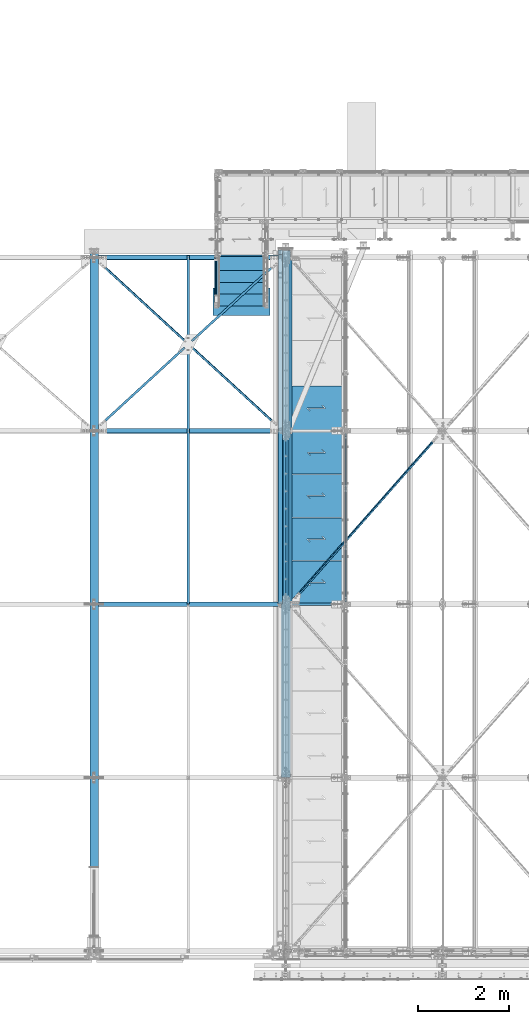
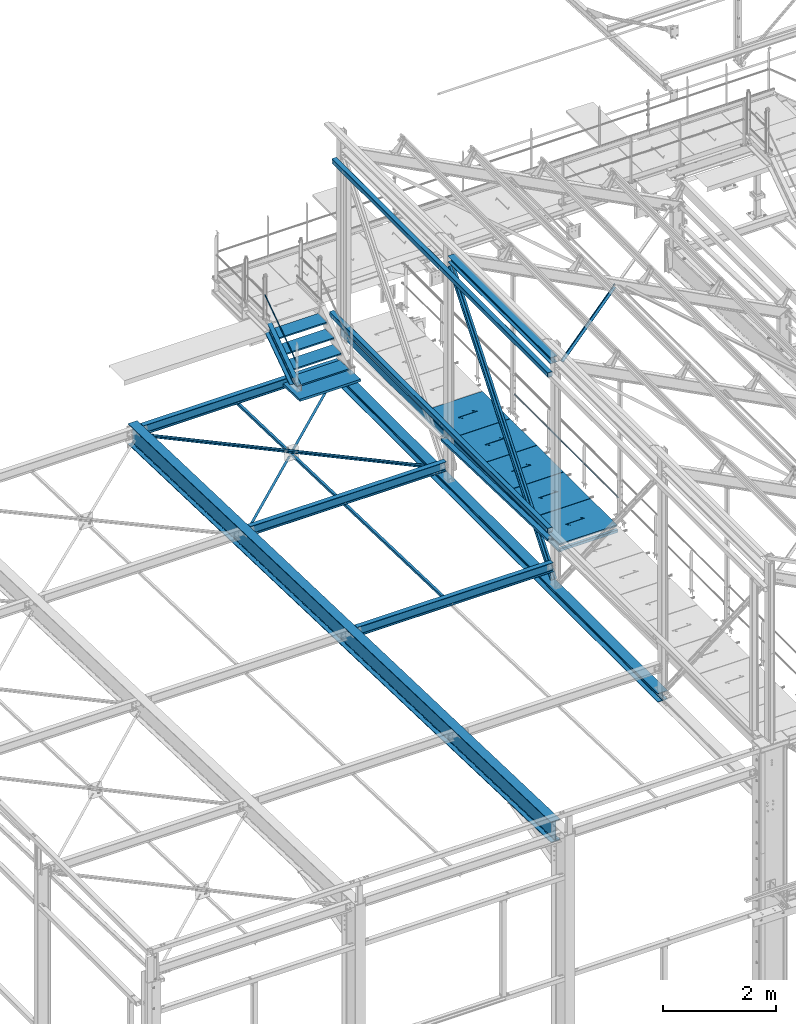
# One storey, part 45 of 496: 27 beams, 4 members, 31 elements without a shape of their own.
"""IFC2X3 building model written with IfcOpenShell, lengths in millimetres."""

import ifcopenshell
import ifcopenshell.guid

model = None  # the IFC model being written
_history = None  # IfcOwnerHistory: only IFC2X3 demands one
_inside = {}  # id of a spatial element -> (the spatial element, [elements in it])
_under = {}  # id of a project, library or spatial element -> (it, [spatial elements below it])
_declared = {}  # id of a project -> (the project, [libraries it declares])
_typed = {}  # id of a type object -> (the type object, [elements of that type])
_made_of = {}  # id of a material, layer set ... -> (it, [elements and type objects made of it])


def new_model(schema):
    """Start an empty IFC model of exactly this schema.

    Asked for "IFC4X3", IfcOpenShell would pick the latest addendum, in which some entities
    have other attributes; the version numbers below select the first issue.
    IFC2X3 requires an IfcOwnerHistory on every rooted entity: one is made here for all.
    """
    global model, _history
    if schema == "IFC4X3":
        model = ifcopenshell.file(schema_version=(4, 3, 0, 0))
    else:
        model = ifcopenshell.file(schema=schema)
    _inside.clear()
    _under.clear()
    _declared.clear()
    _typed.clear()
    _made_of.clear()
    _history = None
    if model.schema == "IFC2X3":
        org = make("IfcOrganization", Name="unknown")
        user = make(
            "IfcPersonAndOrganization",
            ThePerson=make("IfcPerson", FamilyName="unknown"),
            TheOrganization=org,
        )
        app = make(
            "IfcApplication",
            ApplicationDeveloper=org,
            Version="unknown",
            ApplicationFullName="unknown",
            ApplicationIdentifier="unknown",
        )
        _history = make(
            "IfcOwnerHistory",
            OwningUser=user,
            OwningApplication=app,
            ChangeAction="ADDED",
            CreationDate=0,
        )
    return model


def make(cls, **values):
    """One entity of the class cls with the attributes given. An attribute that is None is left unset."""
    return model.create_entity(
        cls, **{name: value for name, value in values.items() if value is not None}
    )


def rooted(cls, **values):
    """An entity with a GlobalId (a new one), such as an element, a storey or a relation."""
    return make(cls, GlobalId=ifcopenshell.guid.new(), OwnerHistory=_history, **values)


def si_unit(unit_type, name, prefix=None):
    """IfcSIUnit, for example si_unit("LENGTHUNIT", "METRE", prefix="MILLI")."""
    return make("IfcSIUnit", UnitType=unit_type, Prefix=prefix, Name=name)


def assignment(units):
    """IfcUnitAssignment: the units of a project."""
    return None if units is None else make("IfcUnitAssignment", Units=units)


def point(xyz):
    """IfcCartesianPoint."""
    return None if xyz is None else make("IfcCartesianPoint", Coordinates=xyz)


def direction(xyz):
    """IfcDirection."""
    return None if xyz is None else make("IfcDirection", DirectionRatios=xyz)


def frame(location, z_axis=None, x_axis=None):
    """IfcAxis2Placement3D, a coordinate frame: its origin and axes. An axis left out is left unset."""
    return make(
        "IfcAxis2Placement3D",
        Location=point(location),
        Axis=direction(z_axis),
        RefDirection=direction(x_axis),
    )


def frame_2d(location, x_axis=None):
    """IfcAxis2Placement2D, a coordinate frame in the plane: its origin and x axis."""
    return make(
        "IfcAxis2Placement2D", Location=point(location), RefDirection=direction(x_axis)
    )


def origin_with_axes():
    """The frame at (0, 0, 0) with the z axis (0, 0, 1) and the x axis (1, 0, 0) written out."""
    return frame((0.0, 0.0, 0.0), z_axis=(0.0, 0.0, 1.0), x_axis=(1.0, 0.0, 0.0))


def origin_2d_with_axis():
    """The frame at (0, 0) in the plane with the x axis (1, 0) written out."""
    return frame_2d((0.0, 0.0), x_axis=(1.0, 0.0))


def place(relative_to, where):
    """IfcLocalPlacement: puts the frame where relative to a parent placement (None: the world)."""
    return make(
        "IfcLocalPlacement", PlacementRelTo=relative_to, RelativePlacement=where
    )


def context(
    kind, dimensions, precision=None, world=None, true_north=None, identifier=None
):
    """IfcGeometricRepresentationContext, for example the 3D "Model" context."""
    return make(
        "IfcGeometricRepresentationContext",
        ContextIdentifier=identifier,
        ContextType=kind,
        CoordinateSpaceDimension=dimensions,
        Precision=precision,
        WorldCoordinateSystem=world,
        TrueNorth=true_north,
    )


def subcontext(parent, identifier, kind, view, scale=None):
    """IfcGeometricRepresentationSubContext, for example "Body" below "Model"."""
    return make(
        "IfcGeometricRepresentationSubContext",
        ContextIdentifier=identifier,
        ContextType=kind,
        ParentContext=parent,
        TargetScale=scale,
        TargetView=view,
    )


def project(units=None, contexts=None):
    """IfcProject with its units and contexts."""
    return rooted(
        "IfcProject",
        Name="project",
        RepresentationContexts=contexts,
        UnitsInContext=assignment(units),
    )


def spatial(cls, under=None, at=None, **own):
    """A site, building, storey or space (cls), placed at a placement, below another one or the project."""
    s = rooted(cls, ObjectPlacement=at, **own)
    if under is not None:
        _under.setdefault(under.id(), (under, []))[1].append(s)
    return s


def polyline(points):
    """IfcPolyline through the points."""
    return make("IfcPolyline", Points=[point(p) for p in points])


def profile(cls, at=None, kind="AREA", **sizes):
    """A parametric profile (cls). Its sizes go by their IFC names, for example OverallWidth=200.0."""
    return make(cls, ProfileType=kind, Position=at, **sizes)


def rectangle(**sizes):
    """IfcRectangleProfileDef."""
    return profile("IfcRectangleProfileDef", **sizes)


def hollow_rectangle(**sizes):
    """IfcRectangleHollowProfileDef."""
    return profile("IfcRectangleHollowProfileDef", **sizes)


def hollow_circle(**sizes):
    """IfcCircleHollowProfileDef."""
    return profile("IfcCircleHollowProfileDef", **sizes)


def i_section(**sizes):
    """IfcIShapeProfileDef."""
    return profile("IfcIShapeProfileDef", **sizes)


def l_section(**sizes):
    """IfcLShapeProfileDef."""
    return profile("IfcLShapeProfileDef", **sizes)


def u_section(**sizes):
    """IfcUShapeProfileDef."""
    return profile("IfcUShapeProfileDef", **sizes)


def outline(outer, holes=None, kind="AREA"):
    """IfcArbitraryClosedProfileDef: a profile drawn as a closed curve; with holes, ...WithVoids."""
    if holes is None:
        return make("IfcArbitraryClosedProfileDef", ProfileType=kind, OuterCurve=outer)
    return make(
        "IfcArbitraryProfileDefWithVoids",
        ProfileType=kind,
        OuterCurve=outer,
        InnerCurves=holes,
    )


def extrude(swept, where, along, depth):
    """IfcExtrudedAreaSolid: the profile swept, set in the frame where, extruded along a direction by depth."""
    return make(
        "IfcExtrudedAreaSolid",
        SweptArea=swept,
        Position=where,
        ExtrudedDirection=direction(along),
        Depth=depth,
    )


def boolean(op, a, b):
    """IfcBooleanResult of two solids."""
    return make("IfcBooleanResult", Operator=op, FirstOperand=a, SecondOperand=b)


def clip(a, b, op="DIFFERENCE"):
    """IfcBooleanClippingResult: the solid a cut by the half space b."""
    return make(
        "IfcBooleanClippingResult", Operator=op, FirstOperand=a, SecondOperand=b
    )


def halfspace(plane, agree):
    """IfcHalfSpaceSolid: all space on one side of the plane z = 0 of the frame plane."""
    return make(
        "IfcHalfSpaceSolid",
        BaseSurface=make("IfcPlane", Position=plane),
        AgreementFlag=agree,
    )


def shape(context_of_items, identifier, shape_type, items):
    """IfcShapeRepresentation: the items that make up one representation, for example the "Body"."""
    return make(
        "IfcShapeRepresentation",
        ContextOfItems=context_of_items,
        RepresentationIdentifier=identifier,
        RepresentationType=shape_type,
        Items=items,
    )


def material(Name=None, Category=None):
    """IfcMaterial."""
    return make("IfcMaterial", Name=Name, Category=Category)


def made_of(thing, what):
    """Note that an element or type object is made of a material, layer set ...; save() writes the relation."""
    if what is not None:
        _made_of.setdefault(what.id(), (what, []))[1].append(thing)
    return thing


def type_object(cls, material=None, **own):
    """A type object (cls), such as IfcWallType, which elements share."""
    return made_of(rooted(cls, **own), material)


def element(
    cls,
    number,
    at=None,
    inside=None,
    cuts=None,
    type_object=None,
    material=None,
    context=None,
    identifier="Body",
    shape_type=None,
    held_by="IfcProductDefinitionShape",
    body=None,
    shapes=None,
    **own,
):
    """One element of the class cls, such as IfcWall. Its Tag is "e" and its number.

    at: its placement. inside: the storey or other place that contains it. cuts: it is an
    opening in that element (IfcRelVoidsElement). A single representation is given by context,
    identifier, shape_type and body (its items); several are given by shapes. held_by: the class
    of the entity that holds the representations. save() writes the other relations.
    """
    e = rooted(cls, Tag="e%d" % number, ObjectPlacement=at, **own)
    if body is not None:
        shapes = [shape(context, identifier, shape_type, body)]
    if shapes is not None:
        e.Representation = make(held_by, Representations=shapes)
    if inside is not None:
        _inside.setdefault(inside.id(), (inside, []))[1].append(e)
    if cuts is not None:
        rooted(
            "IfcRelVoidsElement", RelatingBuildingElement=cuts, RelatedOpeningElement=e
        )
    if type_object is not None:
        _typed.setdefault(type_object.id(), (type_object, []))[1].append(e)
    return made_of(e, material)


def aggregate(whole, parts):
    """IfcRelAggregates: a whole, such as a stair, and the parts it consists of."""
    return rooted("IfcRelAggregates", RelatingObject=whole, RelatedObjects=parts)


def save(model, path):
    """Write the relations noted so far, then the file.

    IfcRelAggregates (storeys below a building ...), IfcRelContainedInSpatialStructure (elements
    in a storey), IfcRelDefinesByType, IfcRelAssociatesMaterial and IfcRelDeclares: one each for
    every whole, place, type object, material and project.
    """
    for whole, parts in _under.values():
        aggregate(whole, parts)
    for where, things in _inside.values():
        rooted(
            "IfcRelContainedInSpatialStructure",
            RelatedElements=things,
            RelatingStructure=where,
        )
    for kind, things in _typed.values():
        rooted("IfcRelDefinesByType", RelatedObjects=things, RelatingType=kind)
    for what, things in _made_of.values():
        rooted("IfcRelAssociatesMaterial", RelatedObjects=things, RelatingMaterial=what)
    for by, libraries in _declared.values():
        rooted("IfcRelDeclares", RelatingContext=by, RelatedDefinitions=libraries)
    model.write(path)


model = new_model("IFC2X3")

# Units and contexts
model_context = context("Model", 3, precision=1e-05, world=origin_with_axes())
body_context = subcontext(model_context, "Body", "Model", "MODEL_VIEW")
ifc_project = project(units=[si_unit("LENGTHUNIT", "METRE", prefix="MILLI"), si_unit("AREAUNIT", "SQUARE_METRE"), si_unit("VOLUMEUNIT", "CUBIC_METRE"), si_unit("MASSUNIT", "GRAM", prefix="KILO"), si_unit("TIMEUNIT", "SECOND"), si_unit("PLANEANGLEUNIT", "RADIAN"), si_unit("SOLIDANGLEUNIT", "STERADIAN"), si_unit("THERMODYNAMICTEMPERATUREUNIT", "DEGREE_CELSIUS"), si_unit("LUMINOUSINTENSITYUNIT", "LUMEN")], contexts=[model_context])

# Site, building, storey
site_placement = place(None, origin_with_axes())
site = spatial("IfcSite", under=ifc_project, at=site_placement, CompositionType="ELEMENT")
building_placement = place(site_placement, origin_with_axes())
building = spatial("IfcBuilding", under=site, at=building_placement, Name="Undefined", CompositionType="ELEMENT")
storey_placement = place(building_placement, origin_with_axes())
storey = spatial("IfcBuildingStorey", under=building, at=storey_placement, Name="Undefined", CompositionType="ELEMENT", Elevation=0.0)

# Assembly, member
assembly_1_placement = place(storey_placement, origin_with_axes())
assembly_1 = element("IfcElementAssembly", 1, at=assembly_1_placement, inside=storey, Name="MAIN COURANTE", AssemblyPlace="NOTDEFINED", PredefinedType="NOTDEFINED")
ifc_material_1 = material(Name="Undefined/S235-E24")
member_type_1 = type_object("IfcMemberType", PredefinedType="NOTDEFINED")
member_1_placement = place(assembly_1_placement, frame((11149.9863365012, 14144.9998536997, 8651.13839395851), z_axis=(-0.999999999999672, -6.66011674184119e-07, -4.61008081401814e-07), x_axis=(0.0, 0.822192191679776, 0.569209978778312)))
member_1 = element("IfcMember", 2, at=member_1_placement, type_object=member_type_1, material=ifc_material_1, Name="LISSE", context=body_context, shape_type="Clipping", body=[
    clip(clip(extrude(hollow_circle(Radius=10.64999962, WallThickness=2.0, at=origin_2d_with_axis()), frame((1395.35433691202, -1.13686837721616e-12, 7.38694435286663e-20), z_axis=(-1.0, 0.0, 0.0), x_axis=(0.0, -1.0, 0.0)), (0.0, 0.0, 1.0), 1404.17), halfspace(frame((1387.78549896895, -10.5802584847571, -0.00112410556539544), z_axis=(-0.822192191679501, -0.569209978778319, 6.66011673795446e-07), x_axis=(0.0, 0.0, -1.0)), True)), halfspace(frame((16.4615054726892, -14.9935154708165, -1.33328503579833e-05), z_axis=(0.822192191679509, 0.569209978778308, -6.6601167379545e-07), x_axis=(-0.569209978778121, 0.822192191679779, 4.61008079582826e-07)), True)),
])
aggregate(assembly_1, [member_1])

# Assembly, beam
assembly_2_placement = place(storey_placement, origin_with_axes())
assembly_2 = element("IfcElementAssembly", 3, at=assembly_2_placement, inside=storey, AssemblyPlace="NOTDEFINED", PredefinedType="NOTDEFINED")
beam_type_1 = type_object("IfcBeamType", PredefinedType="NOTDEFINED")
beam_1_placement = place(assembly_2_placement, frame((10544.7191661259, 13298.0929210154, 7400.97605698723), z_axis=(0.676965821524804, -0.735651264690345, 0.0231191099902681), x_axis=(0.736014467695313, 0.676631800719896, -0.0212628689911977)))
beam_1 = element("IfcBeam", 4, at=beam_1_placement, type_object=beam_type_1, material=ifc_material_1, context=body_context, shape_type="Clipping", body=[
    clip(clip(extrude(l_section(Depth=50.0, Width=50.0, Thickness=5.0, FilletRadius=7.0, EdgeRadius=3.5, at=origin_2d_with_axis()), frame((2808.02895425918, -1.8092470960495e-12, 3.23835093904234e-13), z_axis=(-1.0, 0.0, 0.0), x_axis=(0.0, -1.0, 0.0)), (0.0, 0.0, 1.0), 2754.53), halfspace(frame((2643.02247683221, 25.0000262399835, 25.0000407245411), z_axis=(0.999999999998558, -1.69800000185205e-06, 0.0), x_axis=(-6.7626569939636e-10, 1.60677807515351e-06, -0.999999999998709)), False)), halfspace(frame((105.000008512056, 31.0011373895713, -25.0000000517266), z_axis=(-0.999999999997803, 2.09199999990344e-06, -1.31999999818056e-07), x_axis=(1.69800000215235e-06, 0.999999999998558, 0.0)), False)),
])
aggregate(assembly_2, [beam_1])

assembly_3_placement = place(storey_placement, origin_with_axes())
assembly_3 = element("IfcElementAssembly", 5, at=assembly_3_placement, inside=storey, AssemblyPlace="NOTDEFINED", PredefinedType="NOTDEFINED")
beam_2_placement = place(assembly_3_placement, frame((10543.7500126664, 7601.07123854645, 7586.01904275985), z_axis=(1.0, 0.0, 0.0), x_axis=(0.0, 0.999506556345274, -0.0314108870109058)))
beam_2 = element("IfcBeam", 6, at=beam_2_placement, type_object=beam_type_1, material=ifc_material_1, context=body_context, shape_type="SweptSolid", body=[
    extrude(l_section(Depth=50.0, Width=50.0, Thickness=5.0, FilletRadius=7.0, EdgeRadius=3.5, at=origin_2d_with_axis()), frame((7648.75199419146, 0.0, 0.0), z_axis=(-1.0, 0.0, 0.0), x_axis=(0.0, -1.0, 0.0)), (0.0, 0.0, 1.0), 7648.75),
])
aggregate(assembly_3, [beam_2])

assembly_4_placement = place(storey_placement, origin_with_axes())
assembly_4 = element("IfcElementAssembly", 7, at=assembly_4_placement, inside=storey, AssemblyPlace="NOTDEFINED", PredefinedType="NOTDEFINED")
beam_3_placement = place(assembly_4_placement, frame((8477.96912878436, 11398.0911409512, 7460.68281202055), z_axis=(0.676965821524804, -0.735651264690345, 0.0231191099902681), x_axis=(0.736014467695313, 0.676631800719896, -0.0212628689911977)))
beam_3 = element("IfcBeam", 8, at=beam_3_placement, type_object=beam_type_1, material=ifc_material_1, context=body_context, shape_type="Clipping", body=[
    clip(clip(extrude(l_section(Depth=50.0, Width=50.0, Thickness=5.0, FilletRadius=7.0, EdgeRadius=3.5, at=origin_2d_with_axis()), frame((2754.53355243847, 0.0, 2.44754938186547e-12), z_axis=(-1.0, 0.0, 0.0), x_axis=(0.0, -1.0, 0.0)), (0.0, 0.0, 1.0), 2754.53), halfspace(frame((164.999927370294, -25.0001048205113, 24.9999605355824), z_axis=(-0.999999999998091, 1.45272125142988e-06, -1.3065366643919e-06), x_axis=(1.30653895757013e-06, 1.57853991639855e-06, -0.999999999997901)), False)), halfspace(frame((2703.02910001203, 31.00143768612, -24.9999999943411), z_axis=(-0.999999999997803, 2.09199999990344e-06, -1.31999999818056e-07), x_axis=(1.69800000215235e-06, 0.999999999998558, 0.0)), True)),
])
aggregate(assembly_4, [beam_3])

assembly_5_placement = place(storey_placement, origin_with_axes())
assembly_5 = element("IfcElementAssembly", 9, at=assembly_5_placement, inside=storey, AssemblyPlace="NOTDEFINED", PredefinedType="NOTDEFINED")
beam_4_placement = place(assembly_5_placement, frame((12615.5308974458, 11399.8502253462, 7516.65704241293), z_axis=(-0.676965804548356, -0.735651329870598, 0.0231175329959333), x_axis=(-0.7360144696079, 0.676631798639535, -0.0212628689886725)))
beam_4 = element("IfcBeam", 10, at=beam_4_placement, type_object=beam_type_1, material=ifc_material_1, context=body_context, shape_type="Clipping", body=[
    clip(clip(extrude(l_section(Depth=50.0, Width=50.0, Thickness=5.0, FilletRadius=7.0, EdgeRadius=3.5, at=origin_2d_with_axis()), frame((5616.05806921595, -8.90010086222692e-13, 3.43460813228613e-12), z_axis=(-1.0, 0.0, 0.0), x_axis=(0.0, -1.0, 0.0)), (0.0, 0.0, 1.0), 5616.06), halfspace(frame((5451.05158910555, -25.0000653505249, -25.0000000067885), z_axis=(0.999999999997803, 2.09200000135276e-06, 1.31999999817392e-07), x_axis=(0.0, 0.0, 1.0)), False)), halfspace(frame((164.999980996268, 25.0000653486823, -24.9999999946413), z_axis=(-0.99999999999782, -2.08799998896818e-06, 0.0), x_axis=(0.0, 0.0, 1.0)), False)),
])
aggregate(assembly_5, [beam_4])

# Assembly, member
assembly_6_placement = place(storey_placement, origin_with_axes())
assembly_6 = element("IfcElementAssembly", 11, at=assembly_6_placement, inside=storey, AssemblyPlace="NOTDEFINED", PredefinedType="NOTDEFINED")
ifc_material_2 = material(Name="Undefined/S275-E28")
member_type_2 = type_object("IfcMemberType", Name="UPN260", PredefinedType="NOTDEFINED")
member_2_placement = place(assembly_6_placement, frame((11165.0064946267, 14166.9970857892, 8074.0379599759), z_axis=(2.38199999876088e-06, 0.569209978780056, -0.822192191675118), x_axis=(-1.7169999996433e-06, 0.822192191678566, 0.56920997877747)))
member_2 = element("IfcMember", 12, at=member_2_placement, type_object=member_type_2, material=ifc_material_2, ObjectType="UPN260", context=body_context, shape_type="Clipping", body=[
    clip(clip(clip(extrude(u_section(Depth=260.0, FlangeWidth=90.0, WebThickness=10.0, FlangeThickness=14.0, FilletRadius=14.0, EdgeRadius=7.0, FlangeSlope=0.0798299857122373, at=origin_2d_with_axis()), frame((1401.450854294, -1.81898940354586e-12, 2.27373675443232e-13), z_axis=(-1.0, 0.0, 0.0), x_axis=(0.0, -1.0, 0.0)), (0.0, 0.0, 1.0), 1652.65), halfspace(frame((-194.248465676397, 44.9999999999982, -130.0), z_axis=(-0.594754891759256, -2.93590079459986e-06, 0.803907095826263), x_axis=(0.803907095829729, -3.97667463540568e-10, 0.594754891761818)), False)), halfspace(frame((1199.63884956697, 544.98906444852, 130.001190898261), z_axis=(-0.954513538741863, -9.28664579145766e-07, -0.298167577643217), x_axis=(1.71700000282726e-06, -0.999999999995689, -2.38199999876088e-06)), True)), halfspace(frame((-0.000105426983282086, 106.407623989038, -129.999853760241), z_axis=(0.822192191678561, 5.58458236969708e-08, 0.569209978780065), x_axis=(1.71700000282726e-06, -0.999999999995689, -2.38199999876088e-06)), True)),
])
aggregate(assembly_6, [member_2])

# Assembly, beam
assembly_7_placement = place(storey_placement, origin_with_axes())
assembly_7 = element("IfcElementAssembly", 13, at=assembly_7_placement, inside=storey, Name="Steel Assembly", AssemblyPlace="NOTDEFINED", PredefinedType="NOTDEFINED")
ifc_material_3 = material(Name="POLYURETHANE")
beam_type_2 = type_object("IfcBeamType", PredefinedType="NOTDEFINED")
beam_5_placement = place(assembly_7_placement, frame((11709.9947340707, 14532.1706378134, 7968.49328384745), z_axis=(-1.0, 0.0, 0.0), x_axis=(0.0, -0.999506556345276, 0.031410887010852)))
beam_5 = element("IfcBeam", 14, at=beam_5_placement, type_object=beam_type_2, material=ifc_material_3, context=body_context, shape_type="SweptSolid", body=[
    extrude(rectangle(XDim=50.0, YDim=1250.0, at=origin_2d_with_axis()), frame((600.000000000075, -4.16333634234486e-15, 0.0), z_axis=(-1.0, 0.0, 0.0), x_axis=(0.0, -1.0, 0.0)), (0.0, 0.0, 1.0), 600.0),
])
aggregate(assembly_7, [beam_5])

assembly_8_placement = place(storey_placement, origin_with_axes())
assembly_8 = element("IfcElementAssembly", 15, at=assembly_8_placement, inside=storey, Name="MARCHE", AssemblyPlace="NOTDEFINED", PredefinedType="NOTDEFINED")
beam_type_3 = type_object("IfcBeamType", PredefinedType="NOTDEFINED")
beam_6_placement = place(assembly_8_placement, frame((11709.9938089558, 14444.9997910501, 8145.0000000973), z_axis=(-1.0, 0.0, 0.0), x_axis=(0.0, -1.0, 0.0)))
beam_6 = element("IfcBeam", 16, at=beam_6_placement, type_object=beam_type_3, material=ifc_material_1, Name="MARCHE", context=body_context, shape_type="SweptSolid", body=[
    extrude(rectangle(XDim=30.0, YDim=994.0, at=origin_2d_with_axis()), frame((310.0, 0.0, 0.0), z_axis=(-1.0, 0.0, 0.0), x_axis=(0.0, -1.0, 0.0)), (0.0, 0.0, 1.0), 310.0),
])
aggregate(assembly_8, [beam_6])

assembly_9_placement = place(storey_placement, origin_with_axes())
assembly_9 = element("IfcElementAssembly", 17, at=assembly_9_placement, inside=storey, Name="MARCHE", AssemblyPlace="NOTDEFINED", PredefinedType="NOTDEFINED")
beam_7_placement = place(assembly_9_placement, frame((11709.9938089558, 14704.9997910501, 8325.00000007297), z_axis=(-1.0, 0.0, 0.0), x_axis=(0.0, -1.0, 0.0)))
beam_7 = element("IfcBeam", 18, at=beam_7_placement, type_object=beam_type_3, material=ifc_material_1, Name="MARCHE", context=body_context, shape_type="SweptSolid", body=[
    extrude(rectangle(XDim=30.0, YDim=994.0, at=origin_2d_with_axis()), frame((310.0, 0.0, 0.0), z_axis=(-1.0, 0.0, 0.0), x_axis=(0.0, -1.0, 0.0)), (0.0, 0.0, 1.0), 310.0),
])
aggregate(assembly_9, [beam_7])

assembly_10_placement = place(storey_placement, origin_with_axes())
assembly_10 = element("IfcElementAssembly", 19, at=assembly_10_placement, inside=storey, Name="MARCHE", AssemblyPlace="NOTDEFINED", PredefinedType="NOTDEFINED")
beam_8_placement = place(assembly_10_placement, frame((11709.9938089558, 14964.9997910501, 8505.00000004865), z_axis=(-1.0, 0.0, 0.0), x_axis=(0.0, -1.0, 0.0)))
beam_8 = element("IfcBeam", 20, at=beam_8_placement, type_object=beam_type_3, material=ifc_material_1, Name="MARCHE", context=body_context, shape_type="SweptSolid", body=[
    extrude(rectangle(XDim=30.0, YDim=994.0, at=origin_2d_with_axis()), frame((310.0, 0.0, 0.0), z_axis=(-1.0, 0.0, 0.0), x_axis=(0.0, -1.0, 0.0)), (0.0, 0.0, 1.0), 310.0),
])
aggregate(assembly_10, [beam_8])

assembly_11_placement = place(storey_placement, origin_with_axes())
assembly_11 = element("IfcElementAssembly", 21, at=assembly_11_placement, inside=storey, Name="MARCHE", AssemblyPlace="NOTDEFINED", PredefinedType="NOTDEFINED")
beam_9_placement = place(assembly_11_placement, frame((11709.9938089558, 15224.9997910501, 8685.0), z_axis=(-1.0, 0.0, 0.0), x_axis=(0.0, -1.0, 0.0)))
beam_9 = element("IfcBeam", 22, at=beam_9_placement, type_object=beam_type_3, material=ifc_material_1, Name="MARCHE", context=body_context, shape_type="SweptSolid", body=[
    extrude(rectangle(XDim=30.0, YDim=994.0, at=origin_2d_with_axis()), frame((310.0, 0.0, 0.0), z_axis=(-1.0, 0.0, 0.0), x_axis=(0.0, -1.0, 0.0)), (0.0, 0.0, 1.0), 310.0),
])
aggregate(assembly_11, [beam_9])

assembly_12_placement = place(storey_placement, origin_with_axes())
assembly_12 = element("IfcElementAssembly", 23, at=assembly_12_placement, inside=storey, AssemblyPlace="NOTDEFINED", PredefinedType="NOTDEFINED")
beam_type_4 = type_object("IfcBeamType", PredefinedType="NOTDEFINED")
beam_10_placement = place(assembly_12_placement, frame((12780.6286043737, 7602.1147646699, 12052.4067909751), z_axis=(0.46352885499701, 6.99999093634976e-09, 0.886081824994261), x_axis=(0.62461790718323, 0.709285739208058, -0.32675099109585)))
beam_10 = element("IfcBeam", 24, at=beam_10_placement, type_object=beam_type_4, material=ifc_material_1, context=body_context, shape_type="Clipping", body=[
    clip(clip(extrude(l_section(Depth=60.0, Width=60.0, Thickness=6.0, FilletRadius=8.0, EdgeRadius=4.0, at=origin_2d_with_axis()), frame((5268.62297563985, -3.81630519191158e-13, 3.93044613387294e-12), z_axis=(-1.0, 0.0, 0.0), x_axis=(0.0, -1.0, 0.0)), (0.0, 0.0, 1.0), 5179.74), halfspace(frame((5188.72418157706, 30.0000000230489, -29.9999990786164), z_axis=(-1.0, 0.0, 0.0), x_axis=(0.0, 0.0, 1.0)), True)), halfspace(frame((168.778129372611, -30.0000000141131, -29.9999759833663), z_axis=(1.0, 0.0, 0.0), x_axis=(0.0, 0.0, 1.0)), True)),
])
aggregate(assembly_12, [beam_10])

assembly_13_placement = place(storey_placement, origin_with_axes())
assembly_13 = element("IfcElementAssembly", 25, at=assembly_13_placement, inside=storey, Name="LISSE", AssemblyPlace="NOTDEFINED", PredefinedType="NOTDEFINED")
beam_type_5 = type_object("IfcBeamType", PredefinedType="NOTDEFINED")
beam_11_placement = place(assembly_13_placement, frame((12563.5000000087, 7602.95853913206, 8291.3293909634), z_axis=(1.0, 0.0, 0.0), x_axis=(0.0, 0.999506445341009, -0.0314144190107172)))
beam_11 = element("IfcBeam", 26, at=beam_11_placement, type_object=beam_type_5, material=ifc_material_1, Name="LISSE", context=body_context, shape_type="SweptSolid", body=[
    extrude(u_section(Depth=100.0, FlangeWidth=50.0, WebThickness=4.0, FlangeThickness=4.0, at=origin_2d_with_axis()), frame((3791.87643071007, 0.0, 0.0), z_axis=(-1.0, 0.0, 0.0), x_axis=(0.0, -1.0, 0.0)), (0.0, 0.0, 1.0), 3791.88),
])
aggregate(assembly_13, [beam_11])

assembly_14_placement = place(storey_placement, origin_with_axes())
assembly_14 = element("IfcElementAssembly", 27, at=assembly_14_placement, inside=storey, Name="LISSE", AssemblyPlace="NOTDEFINED", PredefinedType="NOTDEFINED")
beam_type_6 = type_object("IfcBeamType", PredefinedType="NOTDEFINED")
beam_12_placement = place(assembly_14_placement, frame((12563.5000011371, 7604.99999902325, 11869.999999999), z_axis=(0.0, 0.0, -1.0), x_axis=(0.0, 1.0, 0.0)))
beam_12 = element("IfcBeam", 28, at=beam_12_placement, type_object=beam_type_6, material=ifc_material_1, Name="LISSE", context=body_context, shape_type="SweptSolid", body=[
    extrude(hollow_rectangle(XDim=100.0, YDim=100.0, WallThickness=4.0, InnerFilletRadius=4.0, OuterFilletRadius=8.0, at=origin_2d_with_axis()), frame((7664.99999999271, 0.0, 0.0), z_axis=(-1.0, 0.0, 0.0), x_axis=(0.0, -1.0, 0.0)), (0.0, 0.0, 1.0), 7665.0),
])
aggregate(assembly_14, [beam_12])

assembly_15_placement = place(storey_placement, origin_with_axes())
assembly_15 = element("IfcElementAssembly", 29, at=assembly_15_placement, inside=storey, Name="LISSE", AssemblyPlace="NOTDEFINED", PredefinedType="NOTDEFINED")
beam_13_placement = place(assembly_15_placement, frame((12563.499999997, 7604.99999999995, 8499.99999999986), z_axis=(0.0, 0.0, 1.0), x_axis=(0.0, 1.0, 0.0)))
beam_13 = element("IfcBeam", 30, at=beam_13_placement, type_object=beam_type_6, material=ifc_material_1, Name="LISSE", context=body_context, shape_type="SweptSolid", body=[
    extrude(hollow_rectangle(XDim=100.0, YDim=100.0, WallThickness=4.0, InnerFilletRadius=4.0, OuterFilletRadius=8.0, at=origin_2d_with_axis()), frame((7755.0, 0.0, 0.0), z_axis=(-1.0, 0.0, 0.0), x_axis=(0.0, -1.0, 0.0)), (0.0, 0.0, 1.0), 7755.0),
])
aggregate(assembly_15, [beam_13])

assembly_16_placement = place(storey_placement, origin_with_axes())
assembly_16 = element("IfcElementAssembly", 31, at=assembly_16_placement, inside=storey, AssemblyPlace="NOTDEFINED", PredefinedType="NOTDEFINED")
beam_type_7 = type_object("IfcBeamType", PredefinedType="NOTDEFINED")
beam_14_placement = place(assembly_16_placement, frame((13936.4998764003, 12384.9999952307, 8115.0), z_axis=(0.0, 0.0, 1.0), x_axis=(-1.0, 0.0, 0.0)))
beam_14 = element("IfcBeam", 32, at=beam_14_placement, type_object=beam_type_7, material=ifc_material_1, context=body_context, shape_type="CSG", body=[
    boolean("DIFFERENCE", extrude(outline(polyline([(0.0, 0.0), (1179.99169921875, 0.0), (1179.99169921875, 980.0), (-9.39995516091585e-07, 980.0), (0.0, 0.0)])), frame((0.0, 0.0, -15.0), z_axis=(0.0, 0.0, 1.0), x_axis=(1.0, 0.0, 0.0)), (0.0, 0.0, 1.0), 30.0), extrude(outline(polyline([(0.0, 0.0), (9.99999999997453, 6.91215973347425e-11), (10.0000000004329, 75.8578643791443), (282.842712400121, -196.984848017997), (282.842712400743, -96.9848480190813), (272.842712400776, -96.9848480191613), (272.842712400299, -172.842712398218), (0.0, 100.0), (0.0, 0.0)])), frame((724.286946489367, 555.710676888644, -17.5), z_axis=(0.0, 0.0, 1.0), x_axis=(-0.707106781186457, -0.707106781186639, 0.0)), (0.0, 0.0, 1.0), 35.0)),
])
aggregate(assembly_16, [beam_14])

assembly_17_placement = place(storey_placement, origin_with_axes())
assembly_17 = element("IfcElementAssembly", 33, at=assembly_17_placement, inside=storey, AssemblyPlace="NOTDEFINED", PredefinedType="NOTDEFINED")
beam_type_8 = type_object("IfcBeamType", PredefinedType="NOTDEFINED")
beam_15_placement = place(assembly_17_placement, frame((13936.4998764003, 8544.99999523074, 8115.0), z_axis=(0.0, 0.0, 1.0), x_axis=(-1.0, 0.0, 0.0)))
beam_15 = element("IfcBeam", 34, at=beam_15_placement, type_object=beam_type_8, material=ifc_material_1, context=body_context, shape_type="CSG", body=[
    boolean("DIFFERENCE", extrude(outline(polyline([(0.0, 0.0), (1179.99169921875, 0.0), (1179.99169921875, 940.0), (-9.39995516091585e-07, 940.0), (0.0, 0.0)])), frame((0.0, 0.0, -15.0), z_axis=(0.0, 0.0, 1.0), x_axis=(1.0, 0.0, 0.0)), (0.0, 0.0, 1.0), 30.0), extrude(outline(polyline([(0.0, 0.0), (9.99999999997453, 6.91215973347425e-11), (10.0000000004329, 75.8578643791443), (282.842712400121, -196.984848017997), (282.842712400743, -96.9848480190813), (272.842712400776, -96.9848480191613), (272.842712400299, -172.842712398218), (0.0, 100.0), (0.0, 0.0)])), frame((724.286946489367, 535.710676888644, -17.5), z_axis=(0.0, 0.0, 1.0), x_axis=(-0.707106781186457, -0.707106781186639, 0.0)), (0.0, 0.0, 1.0), 35.0)),
])
aggregate(assembly_17, [beam_15])

assembly_18_placement = place(storey_placement, origin_with_axes())
assembly_18 = element("IfcElementAssembly", 35, at=assembly_18_placement, inside=storey, AssemblyPlace="NOTDEFINED", PredefinedType="NOTDEFINED")
beam_16_placement = place(assembly_18_placement, frame((13936.4998821003, 9494.99999523074, 8115.0), z_axis=(0.0, 0.0, 1.0), x_axis=(-1.0, 0.0, 0.0)))
beam_16 = element("IfcBeam", 36, at=beam_16_placement, type_object=beam_type_8, material=ifc_material_1, context=body_context, shape_type="CSG", body=[
    boolean("DIFFERENCE", extrude(outline(polyline([(0.0, 0.0), (1179.99169921875, 0.0), (1179.99169921875, 940.0), (-9.39995516091585e-07, 940.0), (0.0, 0.0)])), frame((0.0, 0.0, -15.0), z_axis=(0.0, 0.0, 1.0), x_axis=(1.0, 0.0, 0.0)), (0.0, 0.0, 1.0), 30.0), extrude(outline(polyline([(0.0, 0.0), (9.99999999997453, 6.91215973347425e-11), (10.0000000004329, 75.8578643791443), (282.842712400121, -196.984848017997), (282.842712400743, -96.9848480190813), (272.842712400776, -96.9848480191613), (272.842712400299, -172.842712398218), (0.0, 100.0), (0.0, 0.0)])), frame((724.286946489367, 535.710676888644, -17.5), z_axis=(0.0, 0.0, 1.0), x_axis=(-0.707106781186457, -0.707106781186639, 0.0)), (0.0, 0.0, 1.0), 35.0)),
])
aggregate(assembly_18, [beam_16])

assembly_19_placement = place(storey_placement, origin_with_axes())
assembly_19 = element("IfcElementAssembly", 37, at=assembly_19_placement, inside=storey, AssemblyPlace="NOTDEFINED", PredefinedType="NOTDEFINED")
beam_17_placement = place(assembly_19_placement, frame((13936.4998878003, 10444.9999952307, 8115.0), z_axis=(0.0, 0.0, 1.0), x_axis=(-1.0, 0.0, 0.0)))
beam_17 = element("IfcBeam", 38, at=beam_17_placement, type_object=beam_type_8, material=ifc_material_1, context=body_context, shape_type="CSG", body=[
    boolean("DIFFERENCE", extrude(outline(polyline([(0.0, 0.0), (1179.99169921875, 0.0), (1179.99169921875, 940.0), (-9.39995516091585e-07, 940.0), (0.0, 0.0)])), frame((0.0, 0.0, -15.0), z_axis=(0.0, 0.0, 1.0), x_axis=(1.0, 0.0, 0.0)), (0.0, 0.0, 1.0), 30.0), extrude(outline(polyline([(0.0, 0.0), (9.99999999997453, 6.91215973347425e-11), (10.0000000004329, 75.8578643791443), (282.842712400121, -196.984848017997), (282.842712400743, -96.9848480190813), (272.842712400776, -96.9848480191613), (272.842712400299, -172.842712398218), (0.0, 100.0), (0.0, 0.0)])), frame((724.286946489367, 535.710676888644, -17.5), z_axis=(0.0, 0.0, 1.0), x_axis=(-0.707106781186457, -0.707106781186639, 0.0)), (0.0, 0.0, 1.0), 35.0)),
])
aggregate(assembly_19, [beam_17])

assembly_20_placement = place(storey_placement, origin_with_axes())
assembly_20 = element("IfcElementAssembly", 39, at=assembly_20_placement, inside=storey, AssemblyPlace="NOTDEFINED", PredefinedType="NOTDEFINED")
beam_18_placement = place(assembly_20_placement, frame((13936.4998935003, 11395.0, 8115.0), z_axis=(0.0, 0.0, 1.0), x_axis=(-1.0, 0.0, 0.0)))
beam_18 = element("IfcBeam", 40, at=beam_18_placement, type_object=beam_type_8, material=ifc_material_1, context=body_context, shape_type="CSG", body=[
    boolean("DIFFERENCE", extrude(outline(polyline([(0.0, 0.0), (1179.99169921875, 0.0), (1179.99169921875, 940.0), (-9.39995516091585e-07, 940.0), (0.0, 0.0)])), frame((0.0, 0.0, -15.0), z_axis=(0.0, 0.0, 1.0), x_axis=(1.0, 0.0, 0.0)), (0.0, 0.0, 1.0), 30.0), extrude(outline(polyline([(0.0, 0.0), (9.99999999997453, 6.91215973347425e-11), (10.0000000004329, 75.8578643791443), (282.842712400121, -196.984848017997), (282.842712400743, -96.9848480190813), (272.842712400776, -96.9848480191613), (272.842712400299, -172.842712398218), (0.0, 100.0), (0.0, 0.0)])), frame((724.286946489367, 535.710676888644, -17.5), z_axis=(0.0, 0.0, 1.0), x_axis=(-0.707106781186457, -0.707106781186639, 0.0)), (0.0, 0.0, 1.0), 35.0)),
])
aggregate(assembly_20, [beam_18])

assembly_21_placement = place(storey_placement, origin_with_axes())
assembly_21 = element("IfcElementAssembly", 41, at=assembly_21_placement, inside=storey, Name="MAIN COURANTE", AssemblyPlace="NOTDEFINED", PredefinedType="NOTDEFINED")
beam_type_9 = type_object("IfcBeamType", PredefinedType="NOTDEFINED")
beam_19_placement = place(assembly_21_placement, frame((13993.9998909316, 11345.0000094402, 8673.79999937563), z_axis=(0.0, 0.0, 1.0), x_axis=(0.0, -1.0, 0.0)))
beam_19 = element("IfcBeam", 42, at=beam_19_placement, type_object=beam_type_9, material=ifc_material_1, Name="LISSE", context=body_context, shape_type="SweptSolid", body=[
    extrude(hollow_circle(Radius=13.44999981, WallThickness=2.0, at=origin_2d_with_axis()), frame((3690.00000000169, 3.69000323827281e-24, 0.0), z_axis=(-1.0, 0.0, 0.0), x_axis=(0.0, -1.0, 0.0)), (0.0, 0.0, 1.0), 3690.0),
])
aggregate(assembly_21, [beam_19])

assembly_22_placement = place(storey_placement, origin_with_axes())
assembly_22 = element("IfcElementAssembly", 43, at=assembly_22_placement, inside=storey, AssemblyPlace="NOTDEFINED", PredefinedType="NOTDEFINED")
beam_type_10 = type_object("IfcBeamType", Name="HEA140", PredefinedType="NOTDEFINED")
beam_20_placement = place(assembly_22_placement, frame((12683.5, 11325.0, 12103.5), z_axis=(0.0, 0.0, 1.0), x_axis=(0.0, -1.0, 0.0)))
beam_20 = element("IfcBeam", 44, at=beam_20_placement, type_object=beam_type_10, material=ifc_material_2, ObjectType="HEA140", context=body_context, shape_type="SweptSolid", body=[
    extrude(i_section(OverallWidth=140.0, OverallDepth=133.0, WebThickness=5.5, FlangeThickness=8.5, FilletRadius=12.0, at=origin_2d_with_axis()), frame((3650.0, 0.0, 0.0), z_axis=(-1.0, 0.0, 0.0), x_axis=(0.0, -1.0, 0.0)), (0.0, 0.0, 1.0), 3650.0),
])
aggregate(assembly_22, [beam_20])

assembly_23_placement = place(storey_placement, origin_with_axes())
assembly_23 = element("IfcElementAssembly", 45, at=assembly_23_placement, inside=storey, AssemblyPlace="NOTDEFINED", PredefinedType="NOTDEFINED")
beam_type_11 = type_object("IfcBeamType", Name="HEA200", PredefinedType="NOTDEFINED")
beam_21_placement = place(assembly_23_placement, frame((12679.9999999993, 15349.9999996071, 7154.99999868158), z_axis=(0.0, 0.0, 1.0), x_axis=(0.0, -1.0, 0.0)))
beam_21 = element("IfcBeam", 46, at=beam_21_placement, type_object=beam_type_11, material=ifc_material_2, ObjectType="HEA200", context=body_context, shape_type="SweptSolid", body=[
    extrude(i_section(OverallWidth=200.0, OverallDepth=190.0, WebThickness=6.5, FlangeThickness=10.0, FilletRadius=18.0, at=origin_2d_with_axis()), frame((11545.0000000265, 0.0, 0.0), z_axis=(-1.0, 0.0, 0.0), x_axis=(0.0, -1.0, 0.0)), (0.0, 0.0, 1.0), 11545.0),
])
aggregate(assembly_23, [beam_21])

assembly_24_placement = place(storey_placement, origin_with_axes())
assembly_24 = element("IfcElementAssembly", 47, at=assembly_24_placement, inside=storey, AssemblyPlace="NOTDEFINED", PredefinedType="NOTDEFINED")
beam_type_12 = type_object("IfcBeamType", PredefinedType="NOTDEFINED")
beam_22_placement = place(assembly_24_placement, frame((12781.5082291039, 7605.00000152288, 8025.0), z_axis=(0.0, 0.0, 1.0), x_axis=(0.0, 1.0, 0.0)))
beam_22 = element("IfcBeam", 48, at=beam_22_placement, type_object=beam_type_12, material=ifc_material_1, context=body_context, shape_type="SweptSolid", body=[
    extrude(u_section(Depth=150.0, FlangeWidth=70.0, WebThickness=5.0, FlangeThickness=5.0, at=origin_2d_with_axis()), frame((7755.0, 0.0, 0.0), z_axis=(-1.0, 0.0, 0.0), x_axis=(0.0, -1.0, 0.0)), (0.0, 0.0, 1.0), 7755.0),
])
aggregate(assembly_24, [beam_22])

# Assembly, member
assembly_25_placement = place(storey_placement, origin_with_axes())
assembly_25 = element("IfcElementAssembly", 49, at=assembly_25_placement, inside=storey, AssemblyPlace="NOTDEFINED", PredefinedType="NOTDEFINED")
member_type_3 = type_object("IfcMemberType", Name="UPN80", PredefinedType="NOTDEFINED")
member_3_placement = place(assembly_25_placement, frame((12707.4999999937, 7599.99999999989, 7250.0), z_axis=(0.0, -0.783225668198107, 0.621737527157264), x_axis=(0.0, 0.621737534986566, 0.783225661983077)))
member_3 = element("IfcMember", 50, at=member_3_placement, type_object=member_type_3, material=ifc_material_2, ObjectType="UPN80", context=body_context, shape_type="Clipping", body=[
    clip(clip(extrude(u_section(Depth=80.0, FlangeWidth=45.0, WebThickness=6.0, FlangeThickness=8.0, FilletRadius=8.0, EdgeRadius=4.0, FlangeSlope=0.0798299857122373, at=origin_2d_with_axis()), frame((6070.59674052178, 0.0, 0.0), z_axis=(-1.0, 0.0, 0.0), x_axis=(0.0, -1.0, 0.0)), (0.0, 0.0, 1.0), 6029.29), halfspace(frame((5991.90387685635, 27.5000000297259, -40.0000004439507), z_axis=(-1.0, 0.0, 0.0), x_axis=(0.0, 1.0, 0.0)), True)), halfspace(frame((119.999999989826, 27.5000000297296, 39.9999985196016), z_axis=(1.0, 0.0, 0.0), x_axis=(0.0, 1.0, 0.0)), True)),
])
aggregate(assembly_25, [member_3])

assembly_26_placement = place(storey_placement, origin_with_axes())
assembly_26 = element("IfcElementAssembly", 51, at=assembly_26_placement, inside=storey, AssemblyPlace="NOTDEFINED", PredefinedType="NOTDEFINED")
member_4_placement = place(assembly_26_placement, frame((12652.5000000274, 11399.9999999993, 12037.0), z_axis=(0.0, -0.783225668198107, 0.621737527157264), x_axis=(0.0, -0.621737527157263, -0.783225668198107)))
member_4 = element("IfcMember", 52, at=member_4_placement, type_object=member_type_3, material=ifc_material_2, ObjectType="UPN80", context=body_context, shape_type="Clipping", body=[
    clip(clip(extrude(u_section(Depth=80.0, FlangeWidth=45.0, WebThickness=6.0, FlangeThickness=8.0, FilletRadius=8.0, EdgeRadius=4.0, FlangeSlope=0.0798299857122373, at=origin_2d_with_axis()), frame((6070.59674052178, 0.0, 0.0), z_axis=(-1.0, 0.0, 0.0), x_axis=(0.0, -1.0, 0.0)), (0.0, 0.0, 1.0), 6029.29), halfspace(frame((5991.90387686459, 27.4999999683569, 39.9999999999964), z_axis=(-1.0, 0.0, 0.0), x_axis=(0.0, -1.0, 0.0)), True)), halfspace(frame((119.999999997919, 27.49999999375, -39.9999989691296), z_axis=(1.0, 0.0, 0.0), x_axis=(0.0, -1.0, 0.0)), True)),
])
aggregate(assembly_26, [member_4])

# Assembly, beam
assembly_27_placement = place(storey_placement, origin_with_axes())
assembly_27 = element("IfcElementAssembly", 53, at=assembly_27_placement, inside=storey, Name="TRAVERSE", AssemblyPlace="NOTDEFINED", PredefinedType="NOTDEFINED")
beam_type_13 = type_object("IfcBeamType", Name="IPE450", PredefinedType="NOTDEFINED")
beam_23_placement = place(assembly_27_placement, frame((8480.00000000071, -7.06742078496467, 7825.11102391607), z_axis=(0.0, -0.031410887010906, -0.999506556345274), x_axis=(0.0, 0.999506556345274, -0.0314108870109058)))
beam_23 = element("IfcBeam", 54, at=beam_23_placement, type_object=beam_type_13, material=ifc_material_2, Name="TRAVERSE", ObjectType="IPE450", context=body_context, shape_type="Clipping", body=[
    clip(clip(extrude(i_section(OverallWidth=190.0, OverallDepth=450.0, WebThickness=9.399999619, FlangeThickness=14.60000038, FilletRadius=21.0, at=origin_2d_with_axis()), frame((15397.5977849943, 0.0, 0.0), z_axis=(-1.0, 0.0, 0.0), x_axis=(0.0, -1.0, 0.0)), (0.0, 0.0, 1.0), 15397.6), halfspace(frame((15367.5829744977, -95.0, -224.999999999999), z_axis=(0.999506560367824, 0.0, -0.0314107590115582), x_axis=(0.0314107590115582, 0.0, 0.999506560367824)), False)), halfspace(frame((335.150577048107, 95.0, -225.471161384995), z_axis=(-0.999506560367824, 0.0, 0.0314107590115593), x_axis=(0.0314107590115582, 0.0, 0.999506560367824)), False)),
])
aggregate(assembly_27, [beam_23])

assembly_28_placement = place(storey_placement, origin_with_axes())
assembly_28 = element("IfcElementAssembly", 55, at=assembly_28_placement, inside=storey, AssemblyPlace="NOTDEFINED", PredefinedType="NOTDEFINED")
beam_type_14 = type_object("IfcBeamType", PredefinedType="NOTDEFINED")
beam_24_placement = place(assembly_28_placement, frame((12758.0083416269, 7600.0, 8015.0), z_axis=(0.0, -1.0, 0.0), x_axis=(1.0, 0.0, 0.0)))
beam_24 = element("IfcBeam", 56, at=beam_24_placement, type_object=beam_type_14, material=ifc_material_1, context=body_context, shape_type="SweptSolid", body=[
    extrude(hollow_rectangle(XDim=60.0, YDim=60.0, WallThickness=3.0, InnerFilletRadius=3.0, OuterFilletRadius=6.0, at=origin_2d_with_axis()), frame((1181.99154388711, 0.0, 0.0), z_axis=(-1.0, 0.0, 0.0), x_axis=(0.0, -1.0, 0.0)), (0.0, 0.0, 1.0), 1181.99),
])
aggregate(assembly_28, [beam_24])

assembly_29_placement = place(storey_placement, origin_with_axes())
assembly_29 = element("IfcElementAssembly", 57, at=assembly_29_placement, inside=storey, AssemblyPlace="NOTDEFINED", PredefinedType="NOTDEFINED")
beam_type_15 = type_object("IfcBeamType", Name="IPE200", PredefinedType="NOTDEFINED")
beam_25_placement = place(assembly_29_placement, frame((8579.99999918653, 15199.9999999821, 7472.27130559981), z_axis=(0.0, 0.031410887010906, 0.999506556345274), x_axis=(1.0, 0.0, 0.0)))
beam_25 = element("IfcBeam", 58, at=beam_25_placement, type_object=beam_type_15, material=ifc_material_2, ObjectType="IPE200", context=body_context, shape_type="SweptSolid", body=[
    extrude(i_section(OverallWidth=100.0, OverallDepth=200.0, WebThickness=5.599999905, FlangeThickness=8.5, FilletRadius=12.0, at=origin_2d_with_axis()), frame((4023.49999999568, 0.0, 0.0), z_axis=(-1.0, 0.0, 0.0), x_axis=(0.0, -1.0, 0.0)), (0.0, 0.0, 1.0), 4023.5),
])
aggregate(assembly_29, [beam_25])

assembly_30_placement = place(storey_placement, origin_with_axes())
assembly_30 = element("IfcElementAssembly", 59, at=assembly_30_placement, inside=storey, AssemblyPlace="NOTDEFINED", PredefinedType="NOTDEFINED")
beam_26_placement = place(assembly_30_placement, frame((8579.99999999835, 11399.9999999843, 7591.69113532052), z_axis=(0.0, 0.031410887010906, 0.999506556345274), x_axis=(1.0, 0.0, 0.0)))
beam_26 = element("IfcBeam", 60, at=beam_26_placement, type_object=beam_type_15, material=ifc_material_2, ObjectType="IPE200", context=body_context, shape_type="SweptSolid", body=[
    extrude(i_section(OverallWidth=100.0, OverallDepth=200.0, WebThickness=5.599999905, FlangeThickness=8.5, FilletRadius=12.0, at=origin_2d_with_axis()), frame((4023.49999999568, 0.0, 0.0), z_axis=(-1.0, 0.0, 0.0), x_axis=(0.0, -1.0, 0.0)), (0.0, 0.0, 1.0), 4023.5),
])
aggregate(assembly_30, [beam_26])

assembly_31_placement = place(storey_placement, origin_with_axes())
assembly_31 = element("IfcElementAssembly", 61, at=assembly_31_placement, inside=storey, AssemblyPlace="NOTDEFINED", PredefinedType="NOTDEFINED")
beam_27_placement = place(assembly_31_placement, frame((8579.99999999889, 7599.99999998665, 7711.11096504123), z_axis=(0.0, 0.031410887010906, 0.999506556345274), x_axis=(1.0, 0.0, 0.0)))
beam_27 = element("IfcBeam", 62, at=beam_27_placement, type_object=beam_type_15, material=ifc_material_2, ObjectType="IPE200", context=body_context, shape_type="SweptSolid", body=[
    extrude(i_section(OverallWidth=100.0, OverallDepth=200.0, WebThickness=5.599999905, FlangeThickness=8.5, FilletRadius=12.0, at=origin_2d_with_axis()), frame((4023.49999999568, 0.0, 0.0), z_axis=(-1.0, 0.0, 0.0), x_axis=(0.0, -1.0, 0.0)), (0.0, 0.0, 1.0), 4023.5),
])
aggregate(assembly_31, [beam_27])

save(model, "model.ifc")
